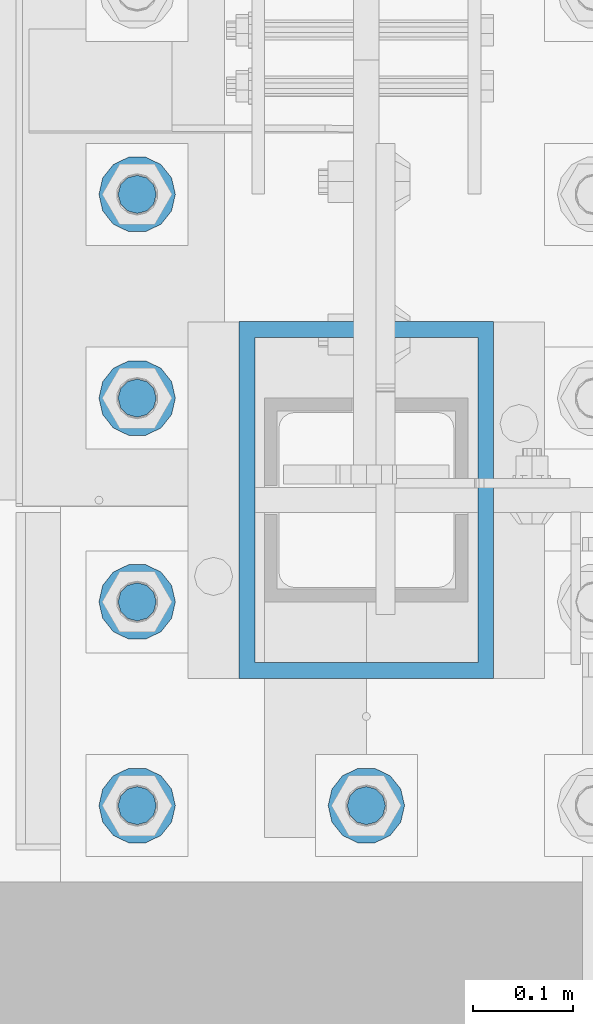
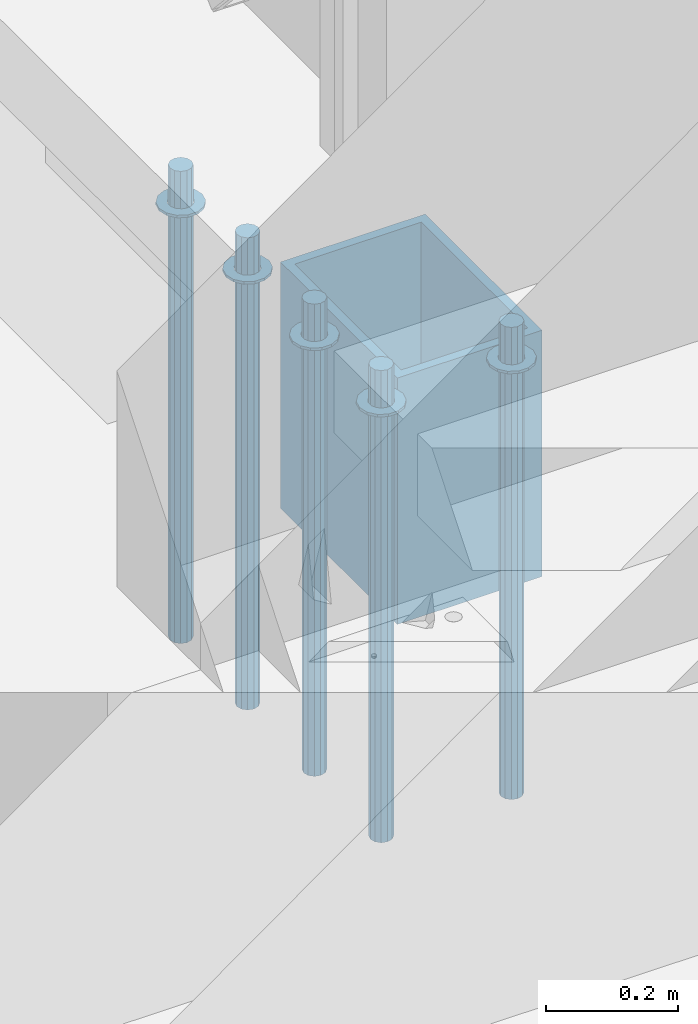
# One storey, part 918 of 1763: 11 columns, 2 elements without a shape of their own.
"""IFC2X3 building model written with IfcOpenShell, lengths in millimetres."""

from ifc_helpers import new_model, si_unit, frame, origin_with_axes, place, context, subcontext, project, spatial, faceted_brep, material, type_object, element, aggregate, save


model = new_model("IFC2X3")

# Units and contexts
model_context = context("Model", 3, precision=1e-05, world=origin_with_axes())
body_context = subcontext(model_context, "Body", "Model", "MODEL_VIEW")
ifc_project = project(units=[si_unit("LENGTHUNIT", "METRE", prefix="MILLI"), si_unit("AREAUNIT", "SQUARE_METRE"), si_unit("VOLUMEUNIT", "CUBIC_METRE"), si_unit("MASSUNIT", "GRAM", prefix="KILO"), si_unit("TIMEUNIT", "SECOND"), si_unit("PLANEANGLEUNIT", "RADIAN"), si_unit("SOLIDANGLEUNIT", "STERADIAN"), si_unit("THERMODYNAMICTEMPERATUREUNIT", "DEGREE_CELSIUS"), si_unit("LUMINOUSINTENSITYUNIT", "LUMEN")], contexts=[model_context])

# Site, building, storey
site_placement = place(None, origin_with_axes())
site = spatial("IfcSite", under=ifc_project, at=site_placement, CompositionType="ELEMENT")
building_placement = place(site_placement, origin_with_axes())
building = spatial("IfcBuilding", under=site, at=building_placement, Name="Undefined", CompositionType="ELEMENT")
storey_placement = place(building_placement, origin_with_axes())
storey = spatial("IfcBuildingStorey", under=building, at=storey_placement, Name="Undefined", CompositionType="ELEMENT", Elevation=0.0)

# Assembly, columns
assembly_1_placement = place(storey_placement, origin_with_axes())
assembly_1 = element("IfcElementAssembly", 1, at=assembly_1_placement, inside=storey, Name="TEMPLATE", AssemblyPlace="NOTDEFINED", PredefinedType="RIGID_FRAME")
ifc_material_1 = material(Name="STEEL/F436")
column_type_1 = type_object("IfcColumnType", Name="1-1/2_WASHER", PredefinedType="NOTDEFINED")
column_1_placement = place(assembly_1_placement, frame((-87604.0372736983, -14020.8, 5151.43750000001), z_axis=(0.0, -1.0, 0.0), x_axis=(0.0, 0.0, -1.0)))
column_1 = element("IfcColumn", 2, at=column_1_placement, type_object=column_type_1, material=ifc_material_1, Name="WASHER", ObjectType="1-1/2_WASHER", context=body_context, shape_type="Brep", body=[
    faceted_brep([(0.0, -38.0999984741211, 0.0), (0.0, -34.3269124923099, -16.5309697983248), (4.76249999999982, -34.3269124923099, -16.5309697983248), (4.76249999999982, -38.0999984741211, 0.0), (0.0, -23.7549604994492, -29.7877782890519), (4.76249999999982, -23.7549604994492, -29.7877782890519), (0.0, -8.47804724419257, -37.1447519665053), (4.76249999999982, -8.47804724419257, -37.1447519665053), (0.0, 8.47804724419257, -37.1447519665053), (4.76249999999982, 8.47804724419257, -37.1447519665053), (0.0, 23.7549604994492, -29.7877782890519), (4.76249999999982, 23.7549604994492, -29.7877782890519), (0.0, 34.3269124923099, -16.5309697983248), (4.76249999999982, 34.3269124923099, -16.5309697983248), (0.0, 38.0999984741211, 0.0), (4.76249999999982, 38.0999984741211, 0.0), (0.0, 34.3269124923099, 16.5309697983248), (4.76249999999982, 34.3269124923099, 16.5309697983248), (0.0, 23.7549604994492, 29.7877782890519), (4.76249999999982, 23.7549604994492, 29.7877782890519), (0.0, 8.47804724419257, 37.1447519665053), (4.76249999999982, 8.47804724419257, 37.1447519665053), (0.0, -8.47804724419257, 37.1447519665053), (4.76249999999982, -8.47804724419257, 37.1447519665053), (0.0, -23.7549604994492, 29.7877782890519), (4.76249999999982, -23.7549604994492, 29.7877782890519), (0.0, -34.3269124923099, 16.5309697983248), (4.76249999999982, -34.3269124923099, 16.5309697983248), (0.0, 0.0, 20.6399993896484), (0.0, 8.95536011056538, 18.5959968835978), (4.76249999999982, 8.95536011056538, 18.5959968835978), (4.76249999999982, 0.0, 20.6399993896484), (0.0, 16.1370013209453, 12.8688291298167), (4.76249999999982, 16.1370013209453, 12.8688291298167), (0.0, 20.1225115123816, 4.59283194104137), (4.76249999999982, 20.1225115123816, 4.59283194104137), (0.0, 20.1225115123816, -4.59283194104319), (4.76249999999982, 20.1225115123816, -4.59283194104319), (0.0, 16.1370013209453, -12.8688291298167), (4.76249999999982, 16.1370013209453, -12.8688291298167), (0.0, 8.95536011056538, -18.5959968835978), (4.76249999999982, 8.95536011056538, -18.5959968835978), (0.0, 0.0, -20.6399993896484), (4.76249999999982, 0.0, -20.6399993896484), (0.0, -8.95536011056538, -18.5959968835978), (4.76249999999982, -8.95536011056538, -18.5959968835978), (0.0, -16.1370013209453, -12.8688291298167), (4.76249999999982, -16.1370013209453, -12.8688291298167), (0.0, -20.1225115123816, -4.59283194104137), (4.76249999999982, -20.1225115123816, -4.59283194104137), (0.0, -20.1225115123816, 4.59283194104319), (4.76249999999982, -20.1225115123816, 4.59283194104319), (0.0, -16.1370013209453, 12.8688291298167), (4.76249999999982, -16.1370013209453, 12.8688291298167), (0.0, -8.95536011056538, 18.5959968835978), (4.76249999999982, -8.95536011056538, 18.5959968835978)], [[[0, 1, 2, 3]], [[1, 4, 5, 2]], [[4, 6, 7, 5]], [[6, 8, 9, 7]], [[8, 10, 11, 9]], [[10, 12, 13, 11]], [[12, 14, 15, 13]], [[14, 16, 17, 15]], [[16, 18, 19, 17]], [[18, 20, 21, 19]], [[20, 22, 23, 21]], [[22, 24, 25, 23]], [[24, 26, 27, 25]], [[26, 0, 3, 27]], [[28, 29, 30, 31]], [[29, 32, 33, 30]], [[32, 34, 35, 33]], [[34, 36, 37, 35]], [[36, 38, 39, 37]], [[38, 40, 41, 39]], [[40, 42, 43, 41]], [[42, 44, 45, 43]], [[44, 46, 47, 45]], [[46, 48, 49, 47]], [[48, 50, 51, 49]], [[50, 52, 53, 51]], [[52, 54, 55, 53]], [[54, 28, 31, 55]], [[5, 7, 9, 11, 13, 15, 17, 19, 21, 23, 25, 27, 3, 2], [33, 35, 37, 39, 41, 43, 45, 47, 49, 51, 53, 55, 31, 30]], [[26, 24, 22, 20, 18, 16, 14, 12, 10, 8, 6, 4, 1, 0], [54, 52, 50, 48, 46, 44, 42, 40, 38, 36, 34, 32, 29, 28]]]),
])
column_2_placement = place(assembly_1_placement, frame((-87375.4372736983, -14020.8, 5151.43750000001), z_axis=(0.0, -1.0, 0.0), x_axis=(0.0, 0.0, -1.0)))
column_2 = element("IfcColumn", 3, at=column_2_placement, type_object=column_type_1, material=ifc_material_1, Name="WASHER", ObjectType="1-1/2_WASHER", context=body_context, shape_type="Brep", body=[
    faceted_brep([(0.0, -38.0999984741211, 0.0), (0.0, -34.3269124923099, -16.5309697983248), (4.76249999999982, -34.3269124923099, -16.5309697983248), (4.76249999999982, -38.0999984741211, 0.0), (0.0, -23.7549604994492, -29.7877782890519), (4.76249999999982, -23.7549604994492, -29.7877782890519), (0.0, -8.47804724419257, -37.1447519665053), (4.76249999999982, -8.47804724419257, -37.1447519665053), (0.0, 8.47804724419257, -37.1447519665053), (4.76249999999982, 8.47804724419257, -37.1447519665053), (0.0, 23.7549604994492, -29.7877782890519), (4.76249999999982, 23.7549604994492, -29.7877782890519), (0.0, 34.3269124923099, -16.5309697983248), (4.76249999999982, 34.3269124923099, -16.5309697983248), (0.0, 38.0999984741211, 0.0), (4.76249999999982, 38.0999984741211, 0.0), (0.0, 34.3269124923099, 16.5309697983248), (4.76249999999982, 34.3269124923099, 16.5309697983248), (0.0, 23.7549604994492, 29.7877782890519), (4.76249999999982, 23.7549604994492, 29.7877782890519), (0.0, 8.47804724419257, 37.1447519665053), (4.76249999999982, 8.47804724419257, 37.1447519665053), (0.0, -8.47804724419257, 37.1447519665053), (4.76249999999982, -8.47804724419257, 37.1447519665053), (0.0, -23.7549604994492, 29.7877782890519), (4.76249999999982, -23.7549604994492, 29.7877782890519), (0.0, -34.3269124923099, 16.5309697983248), (4.76249999999982, -34.3269124923099, 16.5309697983248), (0.0, 0.0, 20.6399993896484), (0.0, 8.95536011056538, 18.5959968835978), (4.76249999999982, 8.95536011056538, 18.5959968835978), (4.76249999999982, 0.0, 20.6399993896484), (0.0, 16.1370013209453, 12.8688291298167), (4.76249999999982, 16.1370013209453, 12.8688291298167), (0.0, 20.1225115123816, 4.59283194104137), (4.76249999999982, 20.1225115123816, 4.59283194104137), (0.0, 20.1225115123816, -4.59283194104319), (4.76249999999982, 20.1225115123816, -4.59283194104319), (0.0, 16.1370013209453, -12.8688291298167), (4.76249999999982, 16.1370013209453, -12.8688291298167), (0.0, 8.95536011056538, -18.5959968835978), (4.76249999999982, 8.95536011056538, -18.5959968835978), (0.0, 0.0, -20.6399993896484), (4.76249999999982, 0.0, -20.6399993896484), (0.0, -8.95536011056538, -18.5959968835978), (4.76249999999982, -8.95536011056538, -18.5959968835978), (0.0, -16.1370013209453, -12.8688291298167), (4.76249999999982, -16.1370013209453, -12.8688291298167), (0.0, -20.1225115123816, -4.59283194104137), (4.76249999999982, -20.1225115123816, -4.59283194104137), (0.0, -20.1225115123816, 4.59283194104319), (4.76249999999982, -20.1225115123816, 4.59283194104319), (0.0, -16.1370013209453, 12.8688291298167), (4.76249999999982, -16.1370013209453, 12.8688291298167), (0.0, -8.95536011056538, 18.5959968835978), (4.76249999999982, -8.95536011056538, 18.5959968835978)], [[[0, 1, 2, 3]], [[1, 4, 5, 2]], [[4, 6, 7, 5]], [[6, 8, 9, 7]], [[8, 10, 11, 9]], [[10, 12, 13, 11]], [[12, 14, 15, 13]], [[14, 16, 17, 15]], [[16, 18, 19, 17]], [[18, 20, 21, 19]], [[20, 22, 23, 21]], [[22, 24, 25, 23]], [[24, 26, 27, 25]], [[26, 0, 3, 27]], [[28, 29, 30, 31]], [[29, 32, 33, 30]], [[32, 34, 35, 33]], [[34, 36, 37, 35]], [[36, 38, 39, 37]], [[38, 40, 41, 39]], [[40, 42, 43, 41]], [[42, 44, 45, 43]], [[44, 46, 47, 45]], [[46, 48, 49, 47]], [[48, 50, 51, 49]], [[50, 52, 53, 51]], [[52, 54, 55, 53]], [[54, 28, 31, 55]], [[5, 7, 9, 11, 13, 15, 17, 19, 21, 23, 25, 27, 3, 2], [33, 35, 37, 39, 41, 43, 45, 47, 49, 51, 53, 55, 31, 30]], [[26, 24, 22, 20, 18, 16, 14, 12, 10, 8, 6, 4, 1, 0], [54, 52, 50, 48, 46, 44, 42, 40, 38, 36, 34, 32, 29, 28]]]),
])
column_3_placement = place(assembly_1_placement, frame((-87604.0372736983, -13817.6, 5151.43750000001), z_axis=(0.0, -1.0, 0.0), x_axis=(0.0, 0.0, -1.0)))
column_3 = element("IfcColumn", 4, at=column_3_placement, type_object=column_type_1, material=ifc_material_1, Name="WASHER", ObjectType="1-1/2_WASHER", context=body_context, shape_type="Brep", body=[
    faceted_brep([(0.0, -38.0999984741211, 0.0), (0.0, -34.3269124923099, -16.5309697983248), (4.76249999999982, -34.3269124923099, -16.5309697983248), (4.76249999999982, -38.0999984741211, 0.0), (0.0, -23.7549604994492, -29.7877782890519), (4.76249999999982, -23.7549604994492, -29.7877782890519), (0.0, -8.47804724419257, -37.1447519665053), (4.76249999999982, -8.47804724419257, -37.1447519665053), (0.0, 8.47804724419257, -37.1447519665053), (4.76249999999982, 8.47804724419257, -37.1447519665053), (0.0, 23.7549604994492, -29.7877782890519), (4.76249999999982, 23.7549604994492, -29.7877782890519), (0.0, 34.3269124923099, -16.5309697983248), (4.76249999999982, 34.3269124923099, -16.5309697983248), (0.0, 38.0999984741211, 0.0), (4.76249999999982, 38.0999984741211, 0.0), (0.0, 34.3269124923099, 16.5309697983248), (4.76249999999982, 34.3269124923099, 16.5309697983248), (0.0, 23.7549604994492, 29.7877782890519), (4.76249999999982, 23.7549604994492, 29.7877782890519), (0.0, 8.47804724419257, 37.1447519665053), (4.76249999999982, 8.47804724419257, 37.1447519665053), (0.0, -8.47804724419257, 37.1447519665053), (4.76249999999982, -8.47804724419257, 37.1447519665053), (0.0, -23.7549604994492, 29.7877782890519), (4.76249999999982, -23.7549604994492, 29.7877782890519), (0.0, -34.3269124923099, 16.5309697983248), (4.76249999999982, -34.3269124923099, 16.5309697983248), (0.0, 0.0, 20.6399993896484), (0.0, 8.95536011056538, 18.5959968835978), (4.76249999999982, 8.95536011056538, 18.5959968835978), (4.76249999999982, 0.0, 20.6399993896484), (0.0, 16.1370013209453, 12.8688291298167), (4.76249999999982, 16.1370013209453, 12.8688291298167), (0.0, 20.1225115123816, 4.59283194104137), (4.76249999999982, 20.1225115123816, 4.59283194104137), (0.0, 20.1225115123816, -4.59283194104319), (4.76249999999982, 20.1225115123816, -4.59283194104319), (0.0, 16.1370013209453, -12.8688291298167), (4.76249999999982, 16.1370013209453, -12.8688291298167), (0.0, 8.95536011056538, -18.5959968835978), (4.76249999999982, 8.95536011056538, -18.5959968835978), (0.0, 0.0, -20.6399993896484), (4.76249999999982, 0.0, -20.6399993896484), (0.0, -8.95536011056538, -18.5959968835978), (4.76249999999982, -8.95536011056538, -18.5959968835978), (0.0, -16.1370013209453, -12.8688291298167), (4.76249999999982, -16.1370013209453, -12.8688291298167), (0.0, -20.1225115123816, -4.59283194104137), (4.76249999999982, -20.1225115123816, -4.59283194104137), (0.0, -20.1225115123816, 4.59283194104319), (4.76249999999982, -20.1225115123816, 4.59283194104319), (0.0, -16.1370013209453, 12.8688291298167), (4.76249999999982, -16.1370013209453, 12.8688291298167), (0.0, -8.95536011056538, 18.5959968835978), (4.76249999999982, -8.95536011056538, 18.5959968835978)], [[[0, 1, 2, 3]], [[1, 4, 5, 2]], [[4, 6, 7, 5]], [[6, 8, 9, 7]], [[8, 10, 11, 9]], [[10, 12, 13, 11]], [[12, 14, 15, 13]], [[14, 16, 17, 15]], [[16, 18, 19, 17]], [[18, 20, 21, 19]], [[20, 22, 23, 21]], [[22, 24, 25, 23]], [[24, 26, 27, 25]], [[26, 0, 3, 27]], [[28, 29, 30, 31]], [[29, 32, 33, 30]], [[32, 34, 35, 33]], [[34, 36, 37, 35]], [[36, 38, 39, 37]], [[38, 40, 41, 39]], [[40, 42, 43, 41]], [[42, 44, 45, 43]], [[44, 46, 47, 45]], [[46, 48, 49, 47]], [[48, 50, 51, 49]], [[50, 52, 53, 51]], [[52, 54, 55, 53]], [[54, 28, 31, 55]], [[5, 7, 9, 11, 13, 15, 17, 19, 21, 23, 25, 27, 3, 2], [33, 35, 37, 39, 41, 43, 45, 47, 49, 51, 53, 55, 31, 30]], [[26, 24, 22, 20, 18, 16, 14, 12, 10, 8, 6, 4, 1, 0], [54, 52, 50, 48, 46, 44, 42, 40, 38, 36, 34, 32, 29, 28]]]),
])
column_4_placement = place(assembly_1_placement, frame((-87604.0372736983, -13614.4, 5151.43750000001), z_axis=(0.0, -1.0, 0.0), x_axis=(0.0, 0.0, -1.0)))
column_4 = element("IfcColumn", 5, at=column_4_placement, type_object=column_type_1, material=ifc_material_1, Name="WASHER", ObjectType="1-1/2_WASHER", context=body_context, shape_type="Brep", body=[
    faceted_brep([(0.0, -38.0999984741211, 0.0), (0.0, -34.3269124923099, -16.5309697983248), (4.76249999999982, -34.3269124923099, -16.5309697983248), (4.76249999999982, -38.0999984741211, 0.0), (0.0, -23.7549604994492, -29.7877782890519), (4.76249999999982, -23.7549604994492, -29.7877782890519), (0.0, -8.47804724419257, -37.1447519665053), (4.76249999999982, -8.47804724419257, -37.1447519665053), (0.0, 8.47804724419257, -37.1447519665053), (4.76249999999982, 8.47804724419257, -37.1447519665053), (0.0, 23.7549604994492, -29.7877782890519), (4.76249999999982, 23.7549604994492, -29.7877782890519), (0.0, 34.3269124923099, -16.5309697983248), (4.76249999999982, 34.3269124923099, -16.5309697983248), (0.0, 38.0999984741211, 0.0), (4.76249999999982, 38.0999984741211, 0.0), (0.0, 34.3269124923099, 16.5309697983248), (4.76249999999982, 34.3269124923099, 16.5309697983248), (0.0, 23.7549604994492, 29.7877782890519), (4.76249999999982, 23.7549604994492, 29.7877782890519), (0.0, 8.47804724419257, 37.1447519665053), (4.76249999999982, 8.47804724419257, 37.1447519665053), (0.0, -8.47804724419257, 37.1447519665053), (4.76249999999982, -8.47804724419257, 37.1447519665053), (0.0, -23.7549604994492, 29.7877782890519), (4.76249999999982, -23.7549604994492, 29.7877782890519), (0.0, -34.3269124923099, 16.5309697983248), (4.76249999999982, -34.3269124923099, 16.5309697983248), (0.0, 0.0, 20.6399993896484), (0.0, 8.95536011056538, 18.5959968835978), (4.76249999999982, 8.95536011056538, 18.5959968835978), (4.76249999999982, 0.0, 20.6399993896484), (0.0, 16.1370013209453, 12.8688291298167), (4.76249999999982, 16.1370013209453, 12.8688291298167), (0.0, 20.1225115123816, 4.59283194104137), (4.76249999999982, 20.1225115123816, 4.59283194104137), (0.0, 20.1225115123816, -4.59283194104319), (4.76249999999982, 20.1225115123816, -4.59283194104319), (0.0, 16.1370013209453, -12.8688291298167), (4.76249999999982, 16.1370013209453, -12.8688291298167), (0.0, 8.95536011056538, -18.5959968835978), (4.76249999999982, 8.95536011056538, -18.5959968835978), (0.0, 0.0, -20.6399993896484), (4.76249999999982, 0.0, -20.6399993896484), (0.0, -8.95536011056538, -18.5959968835978), (4.76249999999982, -8.95536011056538, -18.5959968835978), (0.0, -16.1370013209453, -12.8688291298167), (4.76249999999982, -16.1370013209453, -12.8688291298167), (0.0, -20.1225115123816, -4.59283194104137), (4.76249999999982, -20.1225115123816, -4.59283194104137), (0.0, -20.1225115123816, 4.59283194104319), (4.76249999999982, -20.1225115123816, 4.59283194104319), (0.0, -16.1370013209453, 12.8688291298167), (4.76249999999982, -16.1370013209453, 12.8688291298167), (0.0, -8.95536011056538, 18.5959968835978), (4.76249999999982, -8.95536011056538, 18.5959968835978)], [[[0, 1, 2, 3]], [[1, 4, 5, 2]], [[4, 6, 7, 5]], [[6, 8, 9, 7]], [[8, 10, 11, 9]], [[10, 12, 13, 11]], [[12, 14, 15, 13]], [[14, 16, 17, 15]], [[16, 18, 19, 17]], [[18, 20, 21, 19]], [[20, 22, 23, 21]], [[22, 24, 25, 23]], [[24, 26, 27, 25]], [[26, 0, 3, 27]], [[28, 29, 30, 31]], [[29, 32, 33, 30]], [[32, 34, 35, 33]], [[34, 36, 37, 35]], [[36, 38, 39, 37]], [[38, 40, 41, 39]], [[40, 42, 43, 41]], [[42, 44, 45, 43]], [[44, 46, 47, 45]], [[46, 48, 49, 47]], [[48, 50, 51, 49]], [[50, 52, 53, 51]], [[52, 54, 55, 53]], [[54, 28, 31, 55]], [[5, 7, 9, 11, 13, 15, 17, 19, 21, 23, 25, 27, 3, 2], [33, 35, 37, 39, 41, 43, 45, 47, 49, 51, 53, 55, 31, 30]], [[26, 24, 22, 20, 18, 16, 14, 12, 10, 8, 6, 4, 1, 0], [54, 52, 50, 48, 46, 44, 42, 40, 38, 36, 34, 32, 29, 28]]]),
])
column_5_placement = place(assembly_1_placement, frame((-87604.0372736983, -13411.2, 5151.43750000001), z_axis=(0.0, -1.0, 0.0), x_axis=(0.0, 0.0, -1.0)))
column_5 = element("IfcColumn", 6, at=column_5_placement, type_object=column_type_1, material=ifc_material_1, Name="WASHER", ObjectType="1-1/2_WASHER", context=body_context, shape_type="Brep", body=[
    faceted_brep([(0.0, -38.0999984741211, 0.0), (0.0, -34.3269124923099, -16.5309697983248), (4.76249999999982, -34.3269124923099, -16.5309697983248), (4.76249999999982, -38.0999984741211, 0.0), (0.0, -23.7549604994492, -29.7877782890519), (4.76249999999982, -23.7549604994492, -29.7877782890519), (0.0, -8.47804724419257, -37.1447519665053), (4.76249999999982, -8.47804724419257, -37.1447519665053), (0.0, 8.47804724419257, -37.1447519665053), (4.76249999999982, 8.47804724419257, -37.1447519665053), (0.0, 23.7549604994492, -29.7877782890519), (4.76249999999982, 23.7549604994492, -29.7877782890519), (0.0, 34.3269124923099, -16.5309697983248), (4.76249999999982, 34.3269124923099, -16.5309697983248), (0.0, 38.0999984741211, 0.0), (4.76249999999982, 38.0999984741211, 0.0), (0.0, 34.3269124923099, 16.5309697983248), (4.76249999999982, 34.3269124923099, 16.5309697983248), (0.0, 23.7549604994492, 29.7877782890519), (4.76249999999982, 23.7549604994492, 29.7877782890519), (0.0, 8.47804724419257, 37.1447519665053), (4.76249999999982, 8.47804724419257, 37.1447519665053), (0.0, -8.47804724419257, 37.1447519665053), (4.76249999999982, -8.47804724419257, 37.1447519665053), (0.0, -23.7549604994492, 29.7877782890519), (4.76249999999982, -23.7549604994492, 29.7877782890519), (0.0, -34.3269124923099, 16.5309697983248), (4.76249999999982, -34.3269124923099, 16.5309697983248), (0.0, 0.0, 20.6399993896484), (0.0, 8.95536011056538, 18.5959968835978), (4.76249999999982, 8.95536011056538, 18.5959968835978), (4.76249999999982, 0.0, 20.6399993896484), (0.0, 16.1370013209453, 12.8688291298167), (4.76249999999982, 16.1370013209453, 12.8688291298167), (0.0, 20.1225115123816, 4.59283194104137), (4.76249999999982, 20.1225115123816, 4.59283194104137), (0.0, 20.1225115123816, -4.59283194104319), (4.76249999999982, 20.1225115123816, -4.59283194104319), (0.0, 16.1370013209453, -12.8688291298167), (4.76249999999982, 16.1370013209453, -12.8688291298167), (0.0, 8.95536011056538, -18.5959968835978), (4.76249999999982, 8.95536011056538, -18.5959968835978), (0.0, 0.0, -20.6399993896484), (4.76249999999982, 0.0, -20.6399993896484), (0.0, -8.95536011056538, -18.5959968835978), (4.76249999999982, -8.95536011056538, -18.5959968835978), (0.0, -16.1370013209453, -12.8688291298167), (4.76249999999982, -16.1370013209453, -12.8688291298167), (0.0, -20.1225115123816, -4.59283194104137), (4.76249999999982, -20.1225115123816, -4.59283194104137), (0.0, -20.1225115123816, 4.59283194104319), (4.76249999999982, -20.1225115123816, 4.59283194104319), (0.0, -16.1370013209453, 12.8688291298167), (4.76249999999982, -16.1370013209453, 12.8688291298167), (0.0, -8.95536011056538, 18.5959968835978), (4.76249999999982, -8.95536011056538, 18.5959968835978)], [[[0, 1, 2, 3]], [[1, 4, 5, 2]], [[4, 6, 7, 5]], [[6, 8, 9, 7]], [[8, 10, 11, 9]], [[10, 12, 13, 11]], [[12, 14, 15, 13]], [[14, 16, 17, 15]], [[16, 18, 19, 17]], [[18, 20, 21, 19]], [[20, 22, 23, 21]], [[22, 24, 25, 23]], [[24, 26, 27, 25]], [[26, 0, 3, 27]], [[28, 29, 30, 31]], [[29, 32, 33, 30]], [[32, 34, 35, 33]], [[34, 36, 37, 35]], [[36, 38, 39, 37]], [[38, 40, 41, 39]], [[40, 42, 43, 41]], [[42, 44, 45, 43]], [[44, 46, 47, 45]], [[46, 48, 49, 47]], [[48, 50, 51, 49]], [[50, 52, 53, 51]], [[52, 54, 55, 53]], [[54, 28, 31, 55]], [[5, 7, 9, 11, 13, 15, 17, 19, 21, 23, 25, 27, 3, 2], [33, 35, 37, 39, 41, 43, 45, 47, 49, 51, 53, 55, 31, 30]], [[26, 24, 22, 20, 18, 16, 14, 12, 10, 8, 6, 4, 1, 0], [54, 52, 50, 48, 46, 44, 42, 40, 38, 36, 34, 32, 29, 28]]]),
])
ifc_material_2 = material(Name="STEEL/F1554-GR.55")
column_type_2 = type_object("IfcColumnType", PredefinedType="NOTDEFINED")
column_6_placement = place(assembly_1_placement, frame((-87604.0372736983, -14020.8, 5219.70000000001), z_axis=(0.0, -1.0, 0.0), x_axis=(0.0, 0.0, -1.0)))
column_6 = element("IfcColumn", 7, at=column_6_placement, type_object=column_type_2, material=ifc_material_2, Name="ALL THREADED ROD", context=body_context, shape_type="Brep", body=[
    faceted_brep([(0.0, -19.0500000000029, 0.0), (0.0, -16.4977839420899, -9.52500000000146), (876.299, -16.4977839420899, -9.52499999999964), (876.299, -19.0500000000029, 0.0), (0.0, -9.52499999999418, -16.4977839420935), (876.299, -9.52499999999418, -16.4977839420935), (1.45519152283669e-11, 1.81898940354586e-12, -19.0499999999993), (876.299, 0.0, -19.0500000000002), (0.0, 9.52499999999418, -16.4977839420935), (876.299, 9.52499999999418, -16.4977839420935), (0.0, 16.4977839420899, -9.52500000000146), (876.299, 16.4977839420899, -9.52499999999964), (0.0, 19.0500000000029, 0.0), (876.299, 19.0500000000029, 0.0), (0.0, 16.4977839420899, 9.52500000000146), (876.299, 16.4977839420899, 9.52499999999964), (0.0, 9.52499999999418, 16.4977839420935), (876.299, 9.52499999999418, 16.4977839420935), (1.45519152283669e-11, 1.81898940354586e-12, 19.0499999999993), (876.299, 0.0, 19.0500000000002), (0.0, -9.52499999999418, 16.4977839420935), (876.299, -9.52499999999418, 16.4977839420935), (0.0, -16.4977839420899, 9.52500000000146), (876.299, -16.4977839420899, 9.52499999999964)], [[[0, 1, 2, 3]], [[1, 4, 5, 2]], [[4, 6, 7, 5]], [[6, 8, 9, 7]], [[8, 10, 11, 9]], [[10, 12, 13, 11]], [[12, 14, 15, 13]], [[14, 16, 17, 15]], [[16, 18, 19, 17]], [[18, 20, 21, 19]], [[20, 22, 23, 21]], [[22, 0, 3, 23]], [[5, 7, 9, 11, 13, 15, 17, 19, 21, 23, 3, 2]], [[22, 20, 18, 16, 14, 12, 10, 8, 6, 4, 1, 0]]]),
])
column_7_placement = place(assembly_1_placement, frame((-87375.4372736983, -14020.8, 5219.70000000001), z_axis=(0.0, -1.0, 0.0), x_axis=(0.0, 0.0, -1.0)))
column_7 = element("IfcColumn", 8, at=column_7_placement, type_object=column_type_2, material=ifc_material_2, Name="ALL THREADED ROD", context=body_context, shape_type="Brep", body=[
    faceted_brep([(0.0, -19.0500000000029, 0.0), (0.0, -16.4977839420899, -9.52500000000146), (876.299, -16.4977839420899, -9.52499999999964), (876.299, -19.0500000000029, 0.0), (0.0, -9.52499999999418, -16.4977839420935), (876.299, -9.52499999999418, -16.4977839420935), (1.45519152283669e-11, 1.81898940354586e-12, -19.0499999999993), (876.299, 0.0, -19.0500000000002), (0.0, 9.52499999999418, -16.4977839420935), (876.299, 9.52499999999418, -16.4977839420935), (0.0, 16.4977839420899, -9.52500000000146), (876.299, 16.4977839420899, -9.52499999999964), (0.0, 19.0500000000029, 0.0), (876.299, 19.0500000000029, 0.0), (0.0, 16.4977839420899, 9.52500000000146), (876.299, 16.4977839420899, 9.52499999999964), (0.0, 9.52499999999418, 16.4977839420935), (876.299, 9.52499999999418, 16.4977839420935), (1.45519152283669e-11, 1.81898940354586e-12, 19.0499999999993), (876.299, 0.0, 19.0500000000002), (0.0, -9.52499999999418, 16.4977839420935), (876.299, -9.52499999999418, 16.4977839420935), (0.0, -16.4977839420899, 9.52500000000146), (876.299, -16.4977839420899, 9.52499999999964)], [[[0, 1, 2, 3]], [[1, 4, 5, 2]], [[4, 6, 7, 5]], [[6, 8, 9, 7]], [[8, 10, 11, 9]], [[10, 12, 13, 11]], [[12, 14, 15, 13]], [[14, 16, 17, 15]], [[16, 18, 19, 17]], [[18, 20, 21, 19]], [[20, 22, 23, 21]], [[22, 0, 3, 23]], [[5, 7, 9, 11, 13, 15, 17, 19, 21, 23, 3, 2]], [[22, 20, 18, 16, 14, 12, 10, 8, 6, 4, 1, 0]]]),
])
column_8_placement = place(assembly_1_placement, frame((-87604.0372736983, -13817.6, 5219.70000000001), z_axis=(0.0, -1.0, 0.0), x_axis=(0.0, 0.0, -1.0)))
column_8 = element("IfcColumn", 9, at=column_8_placement, type_object=column_type_2, material=ifc_material_2, Name="ALL THREADED ROD", context=body_context, shape_type="Brep", body=[
    faceted_brep([(0.0, -19.0500000000029, 0.0), (0.0, -16.4977839420899, -9.52500000000146), (876.299, -16.4977839420899, -9.52499999999964), (876.299, -19.0500000000029, 0.0), (0.0, -9.52499999999418, -16.4977839420935), (876.299, -9.52499999999418, -16.4977839420935), (1.45519152283669e-11, 1.81898940354586e-12, -19.0499999999993), (876.299, 0.0, -19.0500000000002), (0.0, 9.52499999999418, -16.4977839420935), (876.299, 9.52499999999418, -16.4977839420935), (0.0, 16.4977839420899, -9.52500000000146), (876.299, 16.4977839420899, -9.52499999999964), (0.0, 19.0500000000029, 0.0), (876.299, 19.0500000000029, 0.0), (0.0, 16.4977839420899, 9.52500000000146), (876.299, 16.4977839420899, 9.52499999999964), (0.0, 9.52499999999418, 16.4977839420935), (876.299, 9.52499999999418, 16.4977839420935), (1.45519152283669e-11, 1.81898940354586e-12, 19.0499999999993), (876.299, 0.0, 19.0500000000002), (0.0, -9.52499999999418, 16.4977839420935), (876.299, -9.52499999999418, 16.4977839420935), (0.0, -16.4977839420899, 9.52500000000146), (876.299, -16.4977839420899, 9.52499999999964)], [[[0, 1, 2, 3]], [[1, 4, 5, 2]], [[4, 6, 7, 5]], [[6, 8, 9, 7]], [[8, 10, 11, 9]], [[10, 12, 13, 11]], [[12, 14, 15, 13]], [[14, 16, 17, 15]], [[16, 18, 19, 17]], [[18, 20, 21, 19]], [[20, 22, 23, 21]], [[22, 0, 3, 23]], [[5, 7, 9, 11, 13, 15, 17, 19, 21, 23, 3, 2]], [[22, 20, 18, 16, 14, 12, 10, 8, 6, 4, 1, 0]]]),
])
column_9_placement = place(assembly_1_placement, frame((-87604.0372736983, -13614.4, 5219.70000000001), z_axis=(0.0, -1.0, 0.0), x_axis=(0.0, 0.0, -1.0)))
column_9 = element("IfcColumn", 10, at=column_9_placement, type_object=column_type_2, material=ifc_material_2, Name="ALL THREADED ROD", context=body_context, shape_type="Brep", body=[
    faceted_brep([(0.0, -19.0500000000029, 0.0), (0.0, -16.4977839420899, -9.52500000000146), (876.299, -16.4977839420899, -9.52499999999964), (876.299, -19.0500000000029, 0.0), (0.0, -9.52499999999418, -16.4977839420935), (876.299, -9.52499999999418, -16.4977839420935), (1.45519152283669e-11, 1.81898940354586e-12, -19.0499999999993), (876.299, 0.0, -19.0500000000002), (0.0, 9.52499999999418, -16.4977839420935), (876.299, 9.52499999999418, -16.4977839420935), (0.0, 16.4977839420899, -9.52500000000146), (876.299, 16.4977839420899, -9.52499999999964), (0.0, 19.0500000000029, 0.0), (876.299, 19.0500000000029, 0.0), (0.0, 16.4977839420899, 9.52500000000146), (876.299, 16.4977839420899, 9.52499999999964), (0.0, 9.52499999999418, 16.4977839420935), (876.299, 9.52499999999418, 16.4977839420935), (1.45519152283669e-11, 1.81898940354586e-12, 19.0499999999993), (876.299, 0.0, 19.0500000000002), (0.0, -9.52499999999418, 16.4977839420935), (876.299, -9.52499999999418, 16.4977839420935), (0.0, -16.4977839420899, 9.52500000000146), (876.299, -16.4977839420899, 9.52499999999964)], [[[0, 1, 2, 3]], [[1, 4, 5, 2]], [[4, 6, 7, 5]], [[6, 8, 9, 7]], [[8, 10, 11, 9]], [[10, 12, 13, 11]], [[12, 14, 15, 13]], [[14, 16, 17, 15]], [[16, 18, 19, 17]], [[18, 20, 21, 19]], [[20, 22, 23, 21]], [[22, 0, 3, 23]], [[5, 7, 9, 11, 13, 15, 17, 19, 21, 23, 3, 2]], [[22, 20, 18, 16, 14, 12, 10, 8, 6, 4, 1, 0]]]),
])
column_10_placement = place(assembly_1_placement, frame((-87604.0372736983, -13411.2, 5219.70000000001), z_axis=(0.0, -1.0, 0.0), x_axis=(0.0, 0.0, -1.0)))
column_10 = element("IfcColumn", 11, at=column_10_placement, type_object=column_type_2, material=ifc_material_2, Name="ALL THREADED ROD", context=body_context, shape_type="Brep", body=[
    faceted_brep([(0.0, -19.0500000000029, 0.0), (0.0, -16.4977839420899, -9.52500000000146), (876.299, -16.4977839420899, -9.52499999999964), (876.299, -19.0500000000029, 0.0), (0.0, -9.52499999999418, -16.4977839420935), (876.299, -9.52499999999418, -16.4977839420935), (1.45519152283669e-11, 1.81898940354586e-12, -19.0499999999993), (876.299, 0.0, -19.0500000000002), (0.0, 9.52499999999418, -16.4977839420935), (876.299, 9.52499999999418, -16.4977839420935), (0.0, 16.4977839420899, -9.52500000000146), (876.299, 16.4977839420899, -9.52499999999964), (0.0, 19.0500000000029, 0.0), (876.299, 19.0500000000029, 0.0), (0.0, 16.4977839420899, 9.52500000000146), (876.299, 16.4977839420899, 9.52499999999964), (0.0, 9.52499999999418, 16.4977839420935), (876.299, 9.52499999999418, 16.4977839420935), (1.45519152283669e-11, 1.81898940354586e-12, 19.0499999999993), (876.299, 0.0, 19.0500000000002), (0.0, -9.52499999999418, 16.4977839420935), (876.299, -9.52499999999418, 16.4977839420935), (0.0, -16.4977839420899, 9.52500000000146), (876.299, -16.4977839420899, 9.52499999999964)], [[[0, 1, 2, 3]], [[1, 4, 5, 2]], [[4, 6, 7, 5]], [[6, 8, 9, 7]], [[8, 10, 11, 9]], [[10, 12, 13, 11]], [[12, 14, 15, 13]], [[14, 16, 17, 15]], [[16, 18, 19, 17]], [[18, 20, 21, 19]], [[20, 22, 23, 21]], [[22, 0, 3, 23]], [[5, 7, 9, 11, 13, 15, 17, 19, 21, 23, 3, 2]], [[22, 20, 18, 16, 14, 12, 10, 8, 6, 4, 1, 0]]]),
])
aggregate(assembly_1, [column_1, column_6, column_2, column_7, column_3, column_8, column_4, column_9, column_5, column_10])

# Assembly, column
assembly_2_placement = place(storey_placement, origin_with_axes())
assembly_2 = element("IfcElementAssembly", 12, at=assembly_2_placement, inside=storey, Name="COLUMN", AssemblyPlace="NOTDEFINED", PredefinedType="RIGID_FRAME")
ifc_material_3 = material()
column_type_3 = type_object("IfcColumnType", Name="HSS14X10X5/8", PredefinedType="NOTDEFINED")
column_11_placement = place(assembly_2_placement, frame((-87375.4372736983, -13716.0, 4622.8), z_axis=(0.0, 1.0, 0.0), x_axis=(0.0, 0.0, 1.0)))
column_11 = element("IfcColumn", 13, at=column_11_placement, type_object=column_type_3, material=ifc_material_3, Name="SHEAR", ObjectType="HSS14X10X5/8", context=body_context, shape_type="Brep", body=[
    faceted_brep([(0.0, 111.125, -161.924999999999), (0.0, -111.125, -161.924999999999), (457.2, -111.125, -161.924999999999), (457.2, 111.125, -161.924999999999), (0.0, -111.125, 161.924999999999), (457.2, -111.125, 161.924999999999), (0.0, 111.125, 161.924999999999), (457.2, 111.125, 161.924999999999), (0.0, 127.0, -177.799999999999), (0.0, 127.0, 177.799999999999), (457.2, 127.0, 177.799999999999), (457.2, 127.0, -177.799999999999), (0.0, -127.0, 177.799999999999), (457.2, -127.0, 177.799999999999), (0.0, -127.0, -177.799999999999), (457.2, -127.0, -177.799999999999)], [[[0, 1, 2, 3]], [[1, 4, 5, 2]], [[4, 6, 7, 5]], [[6, 0, 3, 7]], [[8, 9, 10, 11]], [[9, 12, 13, 10]], [[12, 14, 15, 13]], [[14, 8, 11, 15]], [[13, 15, 11, 10], [5, 7, 3, 2]], [[14, 12, 9, 8], [6, 4, 1, 0]]]),
])
aggregate(assembly_2, [column_11])

save(model, "model.ifc")
